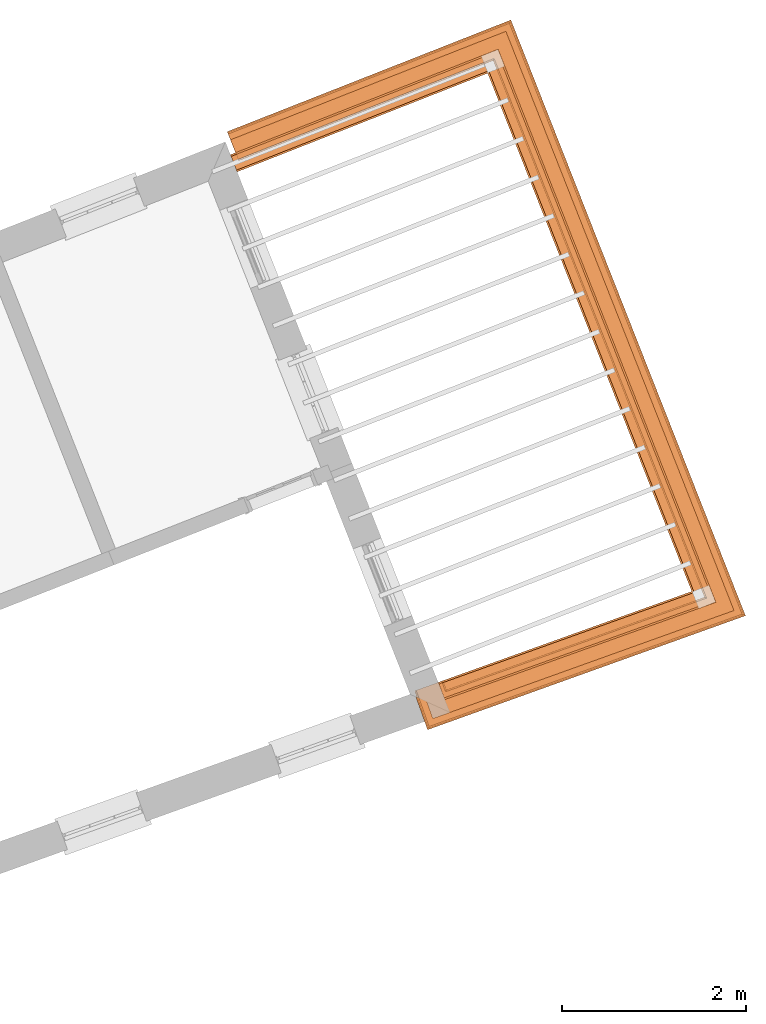
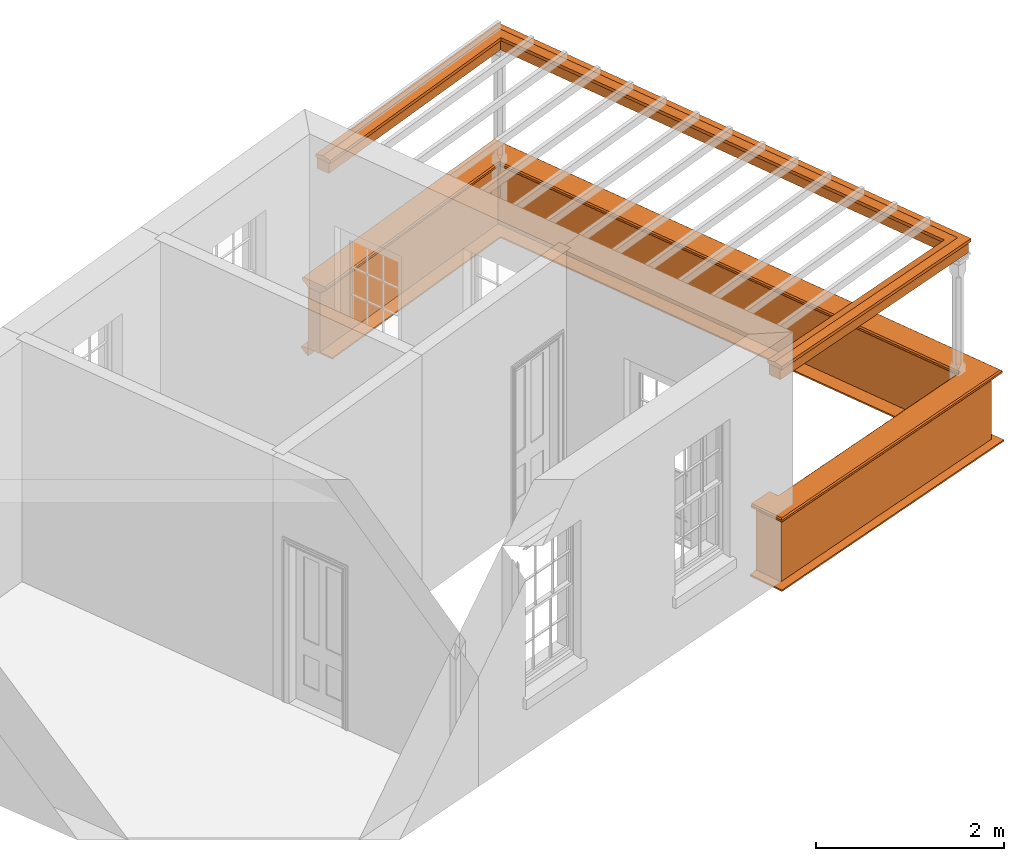
# One storey, part 7 of 8: 5 proxies.
"""IFC2X3 building model written with IfcOpenShell, lengths in metres."""

from ifc_helpers import new_model, entity, si_unit, frame, origin, place, context, subcontext, project, spatial, element, save


model = new_model("IFC2X3")

# Units and contexts
model_context = context("Model", 3, world=origin())
body_context = subcontext(model_context, "Body", "Model", "MODEL_VIEW")
ifc_project = project(units=[si_unit("PLANEANGLEUNIT", "RADIAN"), si_unit("MASSUNIT", "GRAM", prefix="KILO"), si_unit("FORCEUNIT", "NEWTON", prefix="KILO"), si_unit("LENGTHUNIT", "METRE")], contexts=[model_context])

# Site, building, storey
site_placement = place(None, origin())
site = spatial("IfcSite", under=ifc_project, at=site_placement, CompositionType="ELEMENT")
building_placement = place(None, origin())
building = spatial("IfcBuilding", under=site, at=building_placement, Name="Building plot-4", CompositionType="ELEMENT")
storey_placement = place(None, frame((0.0, 0.0, 9.45)))
storey = spatial("IfcBuildingStorey", under=building, at=storey_placement, Name="Floor 2", CompositionType="ELEMENT", Elevation=9.45)

# Proxies
proxy_1_placement = place(storey_placement, origin())
axis2_placement3_d_1 = entity("IfcAxis2Placement3D", entity("IfcCartesianPoint", [0.0, 0.0, 0.0]))
element("IfcBuildingElementProxy", 1, at=proxy_1_placement, inside=storey, Name="parapet", CompositionType="ELEMENT", context=body_context, shape_type="SweptSolid", held_by="IfcProductRepresentation", body=[
    entity("IfcSurfaceCurveSweptAreaSolid", entity("IfcArbitraryClosedProfileDef", "AREA", None, entity("IfcPolyline", [entity("IfcCartesianPoint", [0.0, 0.25]), entity("IfcCartesianPoint", [0.795, 0.25]), entity("IfcCartesianPoint", [0.795, 0.09]), entity("IfcCartesianPoint", [0.02, 0.09]), entity("IfcCartesianPoint", [0.02, -0.08]), entity("IfcCartesianPoint", [0.0, -0.08]), entity("IfcCartesianPoint", [0.0, 0.25])])), axis2_placement3_d_1, entity("IfcPolyline", [entity("IfcCartesianPoint", [54.517546023686, 48.3277510859087]), entity("IfcCartesianPoint", [54.551316186294, 48.2336257645684]), entity("IfcCartesianPoint", [57.3408758489428, 49.2344604185257]), entity("IfcCartesianPoint", [55.0519128662587, 55.0466651468468]), entity("IfcCartesianPoint", [52.2958161296516, 53.9612588850801])]), 0.0, 1.0, entity("IfcPlane", axis2_placement3_d_1)),
])
proxy_2_placement = place(storey_placement, origin())
axis2_placement3_d_2 = entity("IfcAxis2Placement3D", entity("IfcCartesianPoint", [0.0, 0.0, 0.0]))
element("IfcBuildingElementProxy", 2, at=proxy_2_placement, inside=storey, Name="parapet", CompositionType="ELEMENT", context=body_context, shape_type="SweptSolid", held_by="IfcProductRepresentation", body=[
    entity("IfcSurfaceCurveSweptAreaSolid", entity("IfcArbitraryClosedProfileDef", "AREA", None, entity("IfcPolyline", [entity("IfcCartesianPoint", [0.795, 0.265]), entity("IfcCartesianPoint", [0.807, 0.268]), entity("IfcCartesianPoint", [0.816, 0.274]), entity("IfcCartesianPoint", [0.822, 0.283]), entity("IfcCartesianPoint", [0.825, 0.295]), entity("IfcCartesianPoint", [0.84, 0.295]), entity("IfcCartesianPoint", [0.84, 0.305]), entity("IfcCartesianPoint", [0.842, 0.317]), entity("IfcCartesianPoint", [0.849, 0.326]), entity("IfcCartesianPoint", [0.858, 0.333]), entity("IfcCartesianPoint", [0.87, 0.335]), entity("IfcCartesianPoint", [0.882, 0.333]), entity("IfcCartesianPoint", [0.891, 0.326]), entity("IfcCartesianPoint", [0.898, 0.317]), entity("IfcCartesianPoint", [0.9, 0.305]), entity("IfcCartesianPoint", [0.9, 0.035]), entity("IfcCartesianPoint", [0.898, 0.023]), entity("IfcCartesianPoint", [0.891, 0.014]), entity("IfcCartesianPoint", [0.882, 0.007]), entity("IfcCartesianPoint", [0.87, 0.005]), entity("IfcCartesianPoint", [0.858, 0.007]), entity("IfcCartesianPoint", [0.849, 0.014]), entity("IfcCartesianPoint", [0.842, 0.023]), entity("IfcCartesianPoint", [0.84, 0.035]), entity("IfcCartesianPoint", [0.84, 0.045]), entity("IfcCartesianPoint", [0.825, 0.045]), entity("IfcCartesianPoint", [0.822, 0.057]), entity("IfcCartesianPoint", [0.816, 0.066]), entity("IfcCartesianPoint", [0.807, 0.072]), entity("IfcCartesianPoint", [0.795, 0.075]), entity("IfcCartesianPoint", [0.795, 0.265])])), axis2_placement3_d_2, entity("IfcPolyline", [entity("IfcCartesianPoint", [54.517546023686, 48.3277510859087]), entity("IfcCartesianPoint", [54.551316186294, 48.2336257645684]), entity("IfcCartesianPoint", [57.3408758489428, 49.2344604185257]), entity("IfcCartesianPoint", [55.0519128662587, 55.0466651468468]), entity("IfcCartesianPoint", [52.2958161296516, 53.9612588850801])]), 0.0, 1.0, entity("IfcPlane", axis2_placement3_d_2)),
])
proxy_3_placement = place(storey_placement, origin())
axis2_placement3_d_3 = entity("IfcAxis2Placement3D", entity("IfcCartesianPoint", [0.0, 0.0, 0.0]))
element("IfcBuildingElementProxy", 3, at=proxy_3_placement, inside=storey, Name="parapet", CompositionType="ELEMENT", context=body_context, shape_type="SweptSolid", held_by="IfcProductRepresentation", body=[
    entity("IfcSurfaceCurveSweptAreaSolid", entity("IfcArbitraryClosedProfileDef", "AREA", None, entity("IfcPolyline", [entity("IfcCartesianPoint", [-0.1, 0.25]), entity("IfcCartesianPoint", [-0.1, 0.265]), entity("IfcCartesianPoint", [-0.085, 0.265]), entity("IfcCartesianPoint", [-0.084, 0.278]), entity("IfcCartesianPoint", [-0.081, 0.289]), entity("IfcCartesianPoint", [-0.074, 0.301]), entity("IfcCartesianPoint", [-0.065, 0.309]), entity("IfcCartesianPoint", [-0.055, 0.315]), entity("IfcCartesianPoint", [-0.044, 0.324]), entity("IfcCartesianPoint", [-0.038, 0.334]), entity("IfcCartesianPoint", [-0.035, 0.345]), entity("IfcCartesianPoint", [-0.015, 0.345]), entity("IfcCartesianPoint", [0.0, 0.25]), entity("IfcCartesianPoint", [-0.1, 0.25])])), axis2_placement3_d_3, entity("IfcPolyline", [entity("IfcCartesianPoint", [54.517546023686, 48.3277510859087]), entity("IfcCartesianPoint", [54.551316186294, 48.2336257645684]), entity("IfcCartesianPoint", [57.3408758489428, 49.2344604185257]), entity("IfcCartesianPoint", [55.0519128662587, 55.0466651468468]), entity("IfcCartesianPoint", [52.2958161296516, 53.9612588850801])]), 0.0, 1.0, entity("IfcPlane", axis2_placement3_d_3)),
])
proxy_4_placement = place(storey_placement, frame((0.0, 0.0, 3.15)))
axis2_placement3_d_4 = entity("IfcAxis2Placement3D", entity("IfcCartesianPoint", [0.0, 0.0, 0.0]))
element("IfcBuildingElementProxy", 4, at=proxy_4_placement, inside=storey, Name="pergola beam", CompositionType="ELEMENT", context=body_context, shape_type="SweptSolid", held_by="IfcProductRepresentation", body=[
    entity("IfcSurfaceCurveSweptAreaSolid", entity("IfcArbitraryClosedProfileDef", "AREA", None, entity("IfcPolyline", [entity("IfcCartesianPoint", [-0.7, -0.08]), entity("IfcCartesianPoint", [-0.7, 0.08]), entity("IfcCartesianPoint", [-0.56, 0.08]), entity("IfcCartesianPoint", [-0.56, -0.08]), entity("IfcCartesianPoint", [-0.7, -0.08])])), axis2_placement3_d_4, entity("IfcPolyline", [entity("IfcCartesianPoint", [54.4948409934898, 48.2133636670036]), entity("IfcCartesianPoint", [57.3408758489428, 49.2344604185257]), entity("IfcCartesianPoint", [55.0519128662587, 55.0466651468468]), entity("IfcCartesianPoint", [52.2399893550618, 53.9392731797493])]), 0.0, 1.0, entity("IfcPlane", axis2_placement3_d_4)),
])
proxy_5_placement = place(storey_placement, frame((0.0, 0.0, 3.15)))
axis2_placement3_d_5 = entity("IfcAxis2Placement3D", entity("IfcCartesianPoint", [0.0, 0.0, 0.0]))
element("IfcBuildingElementProxy", 5, at=proxy_5_placement, inside=storey, Name="pergola beam", CompositionType="ELEMENT", context=body_context, shape_type="SweptSolid", held_by="IfcProductRepresentation", body=[
    entity("IfcSurfaceCurveSweptAreaSolid", entity("IfcArbitraryClosedProfileDef", "AREA", None, entity("IfcPolyline", [entity("IfcCartesianPoint", [-0.5, 0.0]), entity("IfcCartesianPoint", [-0.52, -0.1]), entity("IfcCartesianPoint", [-0.56, -0.1]), entity("IfcCartesianPoint", [-0.56, 0.1]), entity("IfcCartesianPoint", [-0.52, 0.1]), entity("IfcCartesianPoint", [-0.5, 0.0])])), axis2_placement3_d_5, entity("IfcPolyline", [entity("IfcCartesianPoint", [54.4948409934898, 48.2133636670036]), entity("IfcCartesianPoint", [57.3408758489428, 49.2344604185257]), entity("IfcCartesianPoint", [55.0519128662587, 55.0466651468468]), entity("IfcCartesianPoint", [52.2399893550618, 53.9392731797493])]), 0.0, 1.0, entity("IfcPlane", axis2_placement3_d_5)),
])

save(model, "model.ifc")
